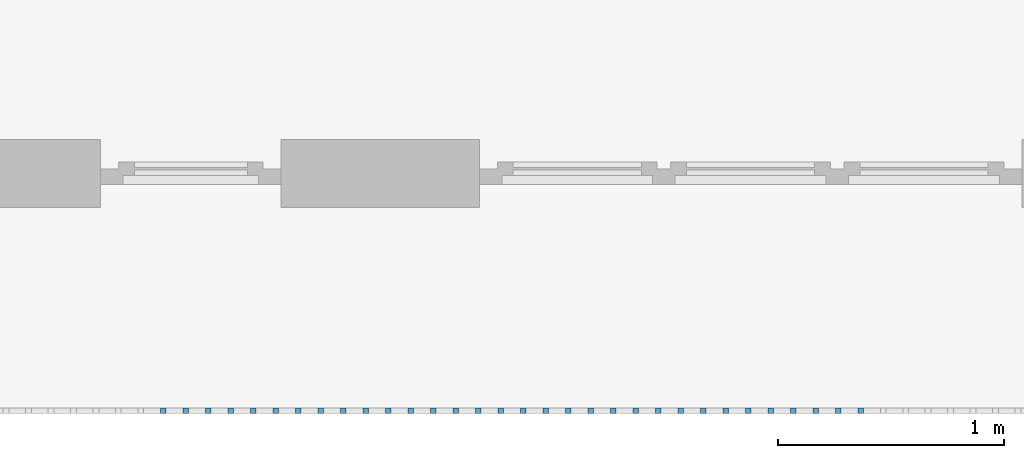
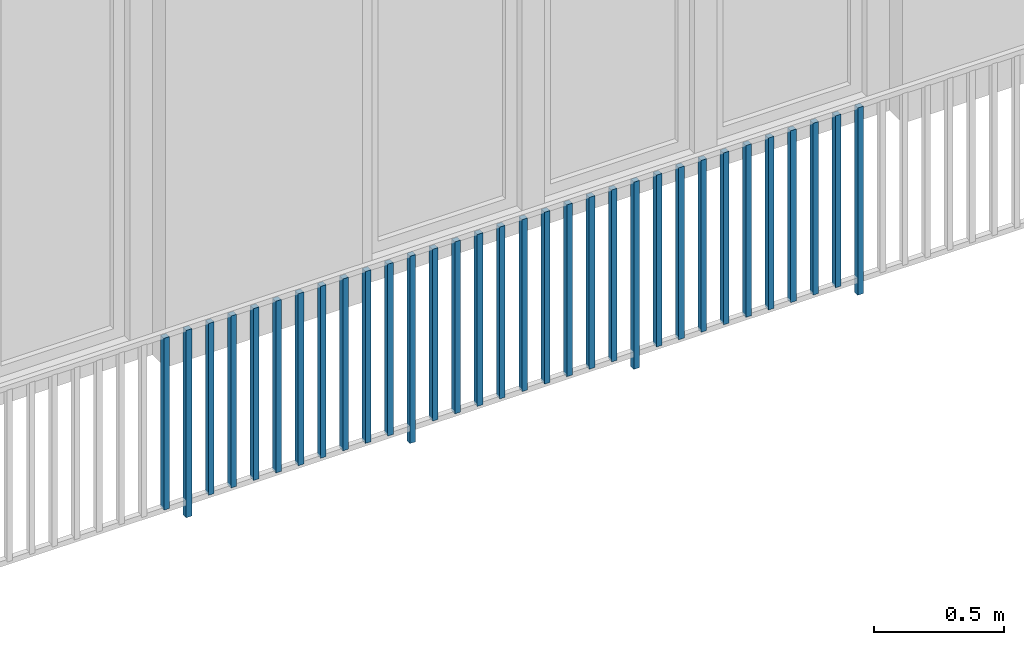
# One storey, part 36 of 54: 32 building element parts, 1 element without a shape of its own.
"""IFC4 building model written with IfcOpenShell, lengths in metres."""

from ifc_helpers import new_model, entity, si_unit, converted_unit, derived_unit, direction, frame, origin_with_axes, place, context, subcontext, project, spatial, polygons, material, type_object, element, aggregate, save


model = new_model("IFC4")

# Units and contexts
model_context = context("Model", 3, precision=1e-05, world=origin_with_axes(), true_north=direction((0.0, 1.0)))
body_context = subcontext(model_context, "Body", "Model", "MODEL_VIEW")
ifc_project = project(units=[si_unit("LENGTHUNIT", "METRE"), si_unit("AREAUNIT", "SQUARE_METRE"), si_unit("VOLUMEUNIT", "CUBIC_METRE"), converted_unit("PLANEANGLEUNIT", "DEGREE", entity("IfcPlaneAngleMeasure", 0.0174532925199), si_unit("PLANEANGLEUNIT", "RADIAN"), dimensions=[0, 0, 0, 0, 0, 0, 0]), converted_unit("TIMEUNIT", "Year", entity("IfcTimeMeasure", 31556926.0), si_unit("TIMEUNIT", "SECOND"), dimensions=[0, 0, 1, 0, 0, 0, 0]), si_unit("MASSUNIT", "GRAM", prefix="KILO"), si_unit("THERMODYNAMICTEMPERATUREUNIT", "DEGREE_CELSIUS"), si_unit("LUMINOUSINTENSITYUNIT", "LUMEN"), si_unit("ENERGYUNIT", "JOULE", prefix="MEGA"), derived_unit("THERMALCONDUCTANCEUNIT", [(si_unit("POWERUNIT", "WATT"), 1), (si_unit("LENGTHUNIT", "METRE"), -1), (si_unit("THERMODYNAMICTEMPERATUREUNIT", "KELVIN"), -1)]), derived_unit("SPECIFICHEATCAPACITYUNIT", [(si_unit("ENERGYUNIT", "JOULE"), 1), (si_unit("MASSUNIT", "GRAM", prefix="KILO"), -1), (si_unit("THERMODYNAMICTEMPERATUREUNIT", "KELVIN"), -1)]), derived_unit("MASSDENSITYUNIT", [(si_unit("MASSUNIT", "GRAM", prefix="KILO"), 1), (si_unit("VOLUMEUNIT", "CUBIC_METRE"), -1)])], contexts=[model_context])

# Site, building, storey, space
site_placement = place(None, origin_with_axes())
site = spatial("IfcSite", under=ifc_project, at=site_placement, CompositionType="ELEMENT")
building_placement = place(site_placement, origin_with_axes())
building = spatial("IfcBuilding", under=site, at=building_placement, CompositionType="ELEMENT")
storey_placement = place(building_placement, frame((0.0, 0.0, 6.29), z_axis=(0.0, 0.0, 1.0), x_axis=(1.0, 0.0, 0.0)))
storey = spatial("IfcBuildingStorey", under=building, at=storey_placement, Name="2. Geschoss", CompositionType="ELEMENT", Elevation=6.29)
space_placement = place(storey_placement, frame((10.2378006196, 9.82118769833, 0.0), z_axis=(0.0, 0.0, 1.0), x_axis=(-1.0, 0.0, 0.0)))
space = spatial("IfcSpace", under=storey, at=space_placement, CompositionType="ELEMENT", PredefinedType="EXTERNAL")

# Railing, building element parts
railing_type = type_object("IfcRailingType", PredefinedType="NOTDEFINED")
railing_placement = place(space_placement, frame((0.0, -7.06315681498e-08, 0.0), z_axis=(0.0, 0.0, 1.0), x_axis=(-1.0, 0.0, 0.0)))
railing = element("IfcRailing", 1, at=railing_placement, inside=space, type_object=railing_type, PredefinedType="NOTDEFINED")
ifc_material = material()
building_element_part_1_placement = place(railing_placement, origin_with_axes())
building_element_part_1 = element("IfcBuildingElementPart", 2, at=building_element_part_1_placement, material=ifc_material, PredefinedType="NOTDEFINED", context=body_context, shape_type="Tessellation", body=[
    polygons([(-10.0348043478, -20.6625, 0.07), (-10.0348043478, -20.6375, 0.07), (-10.0348043478, -20.6375, 0.8775), (-10.0348043478, -20.6625, 0.8775), (-10.0598043478, -20.6625, 0.07), (-10.0598043478, -20.6375, 0.07), (-10.0598043478, -20.6375, 0.8775), (-10.0598043478, -20.6625, 0.8775)], [[[1, 2, 3, 4]], [[1, 5, 6, 2]], [[2, 6, 7, 3]], [[4, 3, 7, 8]], [[5, 1, 4, 8]], [[6, 5, 8, 7]]], closed=True),
])
building_element_part_2_placement = place(railing_placement, origin_with_axes())
building_element_part_2 = element("IfcBuildingElementPart", 3, at=building_element_part_2_placement, material=ifc_material, PredefinedType="NOTDEFINED", context=body_context, shape_type="Tessellation", body=[
    polygons([(-9.93532608696, -20.6625, 0.0), (-9.93532608696, -20.6375, 0.0), (-9.93532608696, -20.6375, 0.88), (-9.93532608696, -20.6625, 0.88), (-9.96032608696, -20.6625, 0.0), (-9.96032608696, -20.6375, 0.0), (-9.96032608696, -20.6375, 0.88), (-9.96032608696, -20.6625, 0.88)], [[[1, 2, 3, 4]], [[1, 5, 6, 2]], [[2, 6, 7, 3]], [[4, 3, 7, 8]], [[5, 1, 4, 8]], [[6, 5, 8, 7]]], closed=True),
])
building_element_part_3_placement = place(railing_placement, origin_with_axes())
building_element_part_3 = element("IfcBuildingElementPart", 4, at=building_element_part_3_placement, material=ifc_material, PredefinedType="NOTDEFINED", context=body_context, shape_type="Tessellation", body=[
    polygons([(-9.83584782609, -20.6625, 0.07), (-9.83584782609, -20.6375, 0.07), (-9.83584782609, -20.6375, 0.8775), (-9.83584782609, -20.6625, 0.8775), (-9.86084782609, -20.6625, 0.07), (-9.86084782609, -20.6375, 0.07), (-9.86084782609, -20.6375, 0.8775), (-9.86084782609, -20.6625, 0.8775)], [[[1, 2, 3, 4]], [[1, 5, 6, 2]], [[2, 6, 7, 3]], [[4, 3, 7, 8]], [[5, 1, 4, 8]], [[6, 5, 8, 7]]], closed=True),
])
building_element_part_4_placement = place(railing_placement, origin_with_axes())
building_element_part_4 = element("IfcBuildingElementPart", 5, at=building_element_part_4_placement, material=ifc_material, PredefinedType="NOTDEFINED", context=body_context, shape_type="Tessellation", body=[
    polygons([(-9.73636956522, -20.6625, 0.07), (-9.73636956522, -20.6375, 0.07), (-9.73636956522, -20.6375, 0.8775), (-9.73636956522, -20.6625, 0.8775), (-9.76136956522, -20.6625, 0.07), (-9.76136956522, -20.6375, 0.07), (-9.76136956522, -20.6375, 0.8775), (-9.76136956522, -20.6625, 0.8775)], [[[1, 2, 3, 4]], [[1, 5, 6, 2]], [[2, 6, 7, 3]], [[4, 3, 7, 8]], [[5, 1, 4, 8]], [[6, 5, 8, 7]]], closed=True),
])
building_element_part_5_placement = place(railing_placement, origin_with_axes())
building_element_part_5 = element("IfcBuildingElementPart", 6, at=building_element_part_5_placement, material=ifc_material, PredefinedType="NOTDEFINED", context=body_context, shape_type="Tessellation", body=[
    polygons([(-9.63689130435, -20.6625, 0.07), (-9.63689130435, -20.6375, 0.07), (-9.63689130435, -20.6375, 0.8775), (-9.63689130435, -20.6625, 0.8775), (-9.66189130435, -20.6625, 0.07), (-9.66189130435, -20.6375, 0.07), (-9.66189130435, -20.6375, 0.8775), (-9.66189130435, -20.6625, 0.8775)], [[[1, 2, 3, 4]], [[1, 5, 6, 2]], [[2, 6, 7, 3]], [[4, 3, 7, 8]], [[5, 1, 4, 8]], [[6, 5, 8, 7]]], closed=True),
])
building_element_part_6_placement = place(railing_placement, origin_with_axes())
building_element_part_6 = element("IfcBuildingElementPart", 7, at=building_element_part_6_placement, material=ifc_material, PredefinedType="NOTDEFINED", context=body_context, shape_type="Tessellation", body=[
    polygons([(-9.53741304348, -20.6625, 0.07), (-9.53741304348, -20.6375, 0.07), (-9.53741304348, -20.6375, 0.8775), (-9.53741304348, -20.6625, 0.8775), (-9.56241304348, -20.6625, 0.07), (-9.56241304348, -20.6375, 0.07), (-9.56241304348, -20.6375, 0.8775), (-9.56241304348, -20.6625, 0.8775)], [[[1, 2, 3, 4]], [[1, 5, 6, 2]], [[2, 6, 7, 3]], [[4, 3, 7, 8]], [[5, 1, 4, 8]], [[6, 5, 8, 7]]], closed=True),
])
building_element_part_7_placement = place(railing_placement, origin_with_axes())
building_element_part_7 = element("IfcBuildingElementPart", 8, at=building_element_part_7_placement, material=ifc_material, PredefinedType="NOTDEFINED", context=body_context, shape_type="Tessellation", body=[
    polygons([(-9.43793478261, -20.6625, 0.07), (-9.43793478261, -20.6375, 0.07), (-9.43793478261, -20.6375, 0.8775), (-9.43793478261, -20.6625, 0.8775), (-9.46293478261, -20.6625, 0.07), (-9.46293478261, -20.6375, 0.07), (-9.46293478261, -20.6375, 0.8775), (-9.46293478261, -20.6625, 0.8775)], [[[1, 2, 3, 4]], [[1, 5, 6, 2]], [[2, 6, 7, 3]], [[4, 3, 7, 8]], [[5, 1, 4, 8]], [[6, 5, 8, 7]]], closed=True),
])
building_element_part_8_placement = place(railing_placement, origin_with_axes())
building_element_part_8 = element("IfcBuildingElementPart", 9, at=building_element_part_8_placement, material=ifc_material, PredefinedType="NOTDEFINED", context=body_context, shape_type="Tessellation", body=[
    polygons([(-9.33845652174, -20.6625, 0.07), (-9.33845652174, -20.6375, 0.07), (-9.33845652174, -20.6375, 0.8775), (-9.33845652174, -20.6625, 0.8775), (-9.36345652174, -20.6625, 0.07), (-9.36345652174, -20.6375, 0.07), (-9.36345652174, -20.6375, 0.8775), (-9.36345652174, -20.6625, 0.8775)], [[[1, 2, 3, 4]], [[1, 5, 6, 2]], [[2, 6, 7, 3]], [[4, 3, 7, 8]], [[5, 1, 4, 8]], [[6, 5, 8, 7]]], closed=True),
])
building_element_part_9_placement = place(railing_placement, origin_with_axes())
building_element_part_9 = element("IfcBuildingElementPart", 10, at=building_element_part_9_placement, material=ifc_material, PredefinedType="NOTDEFINED", context=body_context, shape_type="Tessellation", body=[
    polygons([(-9.23897826087, -20.6625, 0.07), (-9.23897826087, -20.6375, 0.07), (-9.23897826087, -20.6375, 0.8775), (-9.23897826087, -20.6625, 0.8775), (-9.26397826087, -20.6625, 0.07), (-9.26397826087, -20.6375, 0.07), (-9.26397826087, -20.6375, 0.8775), (-9.26397826087, -20.6625, 0.8775)], [[[1, 2, 3, 4]], [[1, 5, 6, 2]], [[2, 6, 7, 3]], [[4, 3, 7, 8]], [[5, 1, 4, 8]], [[6, 5, 8, 7]]], closed=True),
])
building_element_part_10_placement = place(railing_placement, origin_with_axes())
building_element_part_10 = element("IfcBuildingElementPart", 11, at=building_element_part_10_placement, material=ifc_material, PredefinedType="NOTDEFINED", context=body_context, shape_type="Tessellation", body=[
    polygons([(-9.1395, -20.6625, 0.07), (-9.1395, -20.6375, 0.07), (-9.1395, -20.6375, 0.8775), (-9.1395, -20.6625, 0.8775), (-9.1645, -20.6625, 0.07), (-9.1645, -20.6375, 0.07), (-9.1645, -20.6375, 0.8775), (-9.1645, -20.6625, 0.8775)], [[[1, 2, 3, 4]], [[1, 5, 6, 2]], [[2, 6, 7, 3]], [[4, 3, 7, 8]], [[5, 1, 4, 8]], [[6, 5, 8, 7]]], closed=True),
])
building_element_part_11_placement = place(railing_placement, origin_with_axes())
building_element_part_11 = element("IfcBuildingElementPart", 12, at=building_element_part_11_placement, material=ifc_material, PredefinedType="NOTDEFINED", context=body_context, shape_type="Tessellation", body=[
    polygons([(-9.04002173913, -20.6625, 0.07), (-9.04002173913, -20.6375, 0.07), (-9.04002173913, -20.6375, 0.8775), (-9.04002173913, -20.6625, 0.8775), (-9.06502173913, -20.6625, 0.07), (-9.06502173913, -20.6375, 0.07), (-9.06502173913, -20.6375, 0.8775), (-9.06502173913, -20.6625, 0.8775)], [[[1, 2, 3, 4]], [[1, 5, 6, 2]], [[2, 6, 7, 3]], [[4, 3, 7, 8]], [[5, 1, 4, 8]], [[6, 5, 8, 7]]], closed=True),
])
building_element_part_12_placement = place(railing_placement, origin_with_axes())
building_element_part_12 = element("IfcBuildingElementPart", 13, at=building_element_part_12_placement, material=ifc_material, PredefinedType="NOTDEFINED", context=body_context, shape_type="Tessellation", body=[
    polygons([(-8.94054347826, -20.6625, 0.0), (-8.94054347826, -20.6375, 0.0), (-8.94054347826, -20.6375, 0.88), (-8.94054347826, -20.6625, 0.88), (-8.96554347826, -20.6625, 0.0), (-8.96554347826, -20.6375, 0.0), (-8.96554347826, -20.6375, 0.88), (-8.96554347826, -20.6625, 0.88)], [[[1, 2, 3, 4]], [[1, 5, 6, 2]], [[2, 6, 7, 3]], [[4, 3, 7, 8]], [[5, 1, 4, 8]], [[6, 5, 8, 7]]], closed=True),
])
building_element_part_13_placement = place(railing_placement, origin_with_axes())
building_element_part_13 = element("IfcBuildingElementPart", 14, at=building_element_part_13_placement, material=ifc_material, PredefinedType="NOTDEFINED", context=body_context, shape_type="Tessellation", body=[
    polygons([(-8.84106521739, -20.6625, 0.07), (-8.84106521739, -20.6375, 0.07), (-8.84106521739, -20.6375, 0.8775), (-8.84106521739, -20.6625, 0.8775), (-8.86606521739, -20.6625, 0.07), (-8.86606521739, -20.6375, 0.07), (-8.86606521739, -20.6375, 0.8775), (-8.86606521739, -20.6625, 0.8775)], [[[1, 2, 3, 4]], [[1, 5, 6, 2]], [[2, 6, 7, 3]], [[4, 3, 7, 8]], [[5, 1, 4, 8]], [[6, 5, 8, 7]]], closed=True),
])
building_element_part_14_placement = place(railing_placement, origin_with_axes())
building_element_part_14 = element("IfcBuildingElementPart", 15, at=building_element_part_14_placement, material=ifc_material, PredefinedType="NOTDEFINED", context=body_context, shape_type="Tessellation", body=[
    polygons([(-8.74158695652, -20.6625, 0.07), (-8.74158695652, -20.6375, 0.07), (-8.74158695652, -20.6375, 0.8775), (-8.74158695652, -20.6625, 0.8775), (-8.76658695652, -20.6625, 0.07), (-8.76658695652, -20.6375, 0.07), (-8.76658695652, -20.6375, 0.8775), (-8.76658695652, -20.6625, 0.8775)], [[[1, 2, 3, 4]], [[1, 5, 6, 2]], [[2, 6, 7, 3]], [[4, 3, 7, 8]], [[5, 1, 4, 8]], [[6, 5, 8, 7]]], closed=True),
])
building_element_part_15_placement = place(railing_placement, origin_with_axes())
building_element_part_15 = element("IfcBuildingElementPart", 16, at=building_element_part_15_placement, material=ifc_material, PredefinedType="NOTDEFINED", context=body_context, shape_type="Tessellation", body=[
    polygons([(-8.64210869565, -20.6625, 0.07), (-8.64210869565, -20.6375, 0.07), (-8.64210869565, -20.6375, 0.8775), (-8.64210869565, -20.6625, 0.8775), (-8.66710869565, -20.6625, 0.07), (-8.66710869565, -20.6375, 0.07), (-8.66710869565, -20.6375, 0.8775), (-8.66710869565, -20.6625, 0.8775)], [[[1, 2, 3, 4]], [[1, 5, 6, 2]], [[2, 6, 7, 3]], [[4, 3, 7, 8]], [[5, 1, 4, 8]], [[6, 5, 8, 7]]], closed=True),
])
building_element_part_16_placement = place(railing_placement, origin_with_axes())
building_element_part_16 = element("IfcBuildingElementPart", 17, at=building_element_part_16_placement, material=ifc_material, PredefinedType="NOTDEFINED", context=body_context, shape_type="Tessellation", body=[
    polygons([(-8.54263043478, -20.6625, 0.07), (-8.54263043478, -20.6375, 0.07), (-8.54263043478, -20.6375, 0.8775), (-8.54263043478, -20.6625, 0.8775), (-8.56763043478, -20.6625, 0.07), (-8.56763043478, -20.6375, 0.07), (-8.56763043478, -20.6375, 0.8775), (-8.56763043478, -20.6625, 0.8775)], [[[1, 2, 3, 4]], [[1, 5, 6, 2]], [[2, 6, 7, 3]], [[4, 3, 7, 8]], [[5, 1, 4, 8]], [[6, 5, 8, 7]]], closed=True),
])
building_element_part_17_placement = place(railing_placement, origin_with_axes())
building_element_part_17 = element("IfcBuildingElementPart", 18, at=building_element_part_17_placement, material=ifc_material, PredefinedType="NOTDEFINED", context=body_context, shape_type="Tessellation", body=[
    polygons([(-8.44315217391, -20.6625, 0.07), (-8.44315217391, -20.6375, 0.07), (-8.44315217391, -20.6375, 0.8775), (-8.44315217391, -20.6625, 0.8775), (-8.46815217391, -20.6625, 0.07), (-8.46815217391, -20.6375, 0.07), (-8.46815217391, -20.6375, 0.8775), (-8.46815217391, -20.6625, 0.8775)], [[[1, 2, 3, 4]], [[1, 5, 6, 2]], [[2, 6, 7, 3]], [[4, 3, 7, 8]], [[5, 1, 4, 8]], [[6, 5, 8, 7]]], closed=True),
])
building_element_part_18_placement = place(railing_placement, origin_with_axes())
building_element_part_18 = element("IfcBuildingElementPart", 19, at=building_element_part_18_placement, material=ifc_material, PredefinedType="NOTDEFINED", context=body_context, shape_type="Tessellation", body=[
    polygons([(-8.34367391304, -20.6625, 0.07), (-8.34367391304, -20.6375, 0.07), (-8.34367391304, -20.6375, 0.8775), (-8.34367391304, -20.6625, 0.8775), (-8.36867391304, -20.6625, 0.07), (-8.36867391304, -20.6375, 0.07), (-8.36867391304, -20.6375, 0.8775), (-8.36867391304, -20.6625, 0.8775)], [[[1, 2, 3, 4]], [[1, 5, 6, 2]], [[2, 6, 7, 3]], [[4, 3, 7, 8]], [[5, 1, 4, 8]], [[6, 5, 8, 7]]], closed=True),
])
building_element_part_19_placement = place(railing_placement, origin_with_axes())
building_element_part_19 = element("IfcBuildingElementPart", 20, at=building_element_part_19_placement, material=ifc_material, PredefinedType="NOTDEFINED", context=body_context, shape_type="Tessellation", body=[
    polygons([(-8.24419565217, -20.6625, 0.07), (-8.24419565217, -20.6375, 0.07), (-8.24419565217, -20.6375, 0.8775), (-8.24419565217, -20.6625, 0.8775), (-8.26919565217, -20.6625, 0.07), (-8.26919565217, -20.6375, 0.07), (-8.26919565217, -20.6375, 0.8775), (-8.26919565217, -20.6625, 0.8775)], [[[1, 2, 3, 4]], [[1, 5, 6, 2]], [[2, 6, 7, 3]], [[4, 3, 7, 8]], [[5, 1, 4, 8]], [[6, 5, 8, 7]]], closed=True),
])
building_element_part_20_placement = place(railing_placement, origin_with_axes())
building_element_part_20 = element("IfcBuildingElementPart", 21, at=building_element_part_20_placement, material=ifc_material, PredefinedType="NOTDEFINED", context=body_context, shape_type="Tessellation", body=[
    polygons([(-8.1447173913, -20.6625, 0.07), (-8.1447173913, -20.6375, 0.07), (-8.1447173913, -20.6375, 0.8775), (-8.1447173913, -20.6625, 0.8775), (-8.1697173913, -20.6625, 0.07), (-8.1697173913, -20.6375, 0.07), (-8.1697173913, -20.6375, 0.8775), (-8.1697173913, -20.6625, 0.8775)], [[[1, 2, 3, 4]], [[1, 5, 6, 2]], [[2, 6, 7, 3]], [[4, 3, 7, 8]], [[5, 1, 4, 8]], [[6, 5, 8, 7]]], closed=True),
])
building_element_part_21_placement = place(railing_placement, origin_with_axes())
building_element_part_21 = element("IfcBuildingElementPart", 22, at=building_element_part_21_placement, material=ifc_material, PredefinedType="NOTDEFINED", context=body_context, shape_type="Tessellation", body=[
    polygons([(-8.04523913043, -20.6625, 0.07), (-8.04523913043, -20.6375, 0.07), (-8.04523913043, -20.6375, 0.8775), (-8.04523913043, -20.6625, 0.8775), (-8.07023913043, -20.6625, 0.07), (-8.07023913043, -20.6375, 0.07), (-8.07023913043, -20.6375, 0.8775), (-8.07023913043, -20.6625, 0.8775)], [[[1, 2, 3, 4]], [[1, 5, 6, 2]], [[2, 6, 7, 3]], [[4, 3, 7, 8]], [[5, 1, 4, 8]], [[6, 5, 8, 7]]], closed=True),
])
building_element_part_22_placement = place(railing_placement, origin_with_axes())
building_element_part_22 = element("IfcBuildingElementPart", 23, at=building_element_part_22_placement, material=ifc_material, PredefinedType="NOTDEFINED", context=body_context, shape_type="Tessellation", body=[
    polygons([(-7.94576086957, -20.6625, 0.0), (-7.94576086957, -20.6375, 0.0), (-7.94576086957, -20.6375, 0.88), (-7.94576086957, -20.6625, 0.88), (-7.97076086957, -20.6625, 0.0), (-7.97076086957, -20.6375, 0.0), (-7.97076086957, -20.6375, 0.88), (-7.97076086957, -20.6625, 0.88)], [[[1, 2, 3, 4]], [[1, 5, 6, 2]], [[2, 6, 7, 3]], [[4, 3, 7, 8]], [[5, 1, 4, 8]], [[6, 5, 8, 7]]], closed=True),
])
building_element_part_23_placement = place(railing_placement, origin_with_axes())
building_element_part_23 = element("IfcBuildingElementPart", 24, at=building_element_part_23_placement, material=ifc_material, PredefinedType="NOTDEFINED", context=body_context, shape_type="Tessellation", body=[
    polygons([(-7.8462826087, -20.6625, 0.07), (-7.8462826087, -20.6375, 0.07), (-7.8462826087, -20.6375, 0.8775), (-7.8462826087, -20.6625, 0.8775), (-7.8712826087, -20.6625, 0.07), (-7.8712826087, -20.6375, 0.07), (-7.8712826087, -20.6375, 0.8775), (-7.8712826087, -20.6625, 0.8775)], [[[1, 2, 3, 4]], [[1, 5, 6, 2]], [[2, 6, 7, 3]], [[4, 3, 7, 8]], [[5, 1, 4, 8]], [[6, 5, 8, 7]]], closed=True),
])
building_element_part_24_placement = place(railing_placement, origin_with_axes())
building_element_part_24 = element("IfcBuildingElementPart", 25, at=building_element_part_24_placement, material=ifc_material, PredefinedType="NOTDEFINED", context=body_context, shape_type="Tessellation", body=[
    polygons([(-7.74680434783, -20.6625, 0.07), (-7.74680434783, -20.6375, 0.07), (-7.74680434783, -20.6375, 0.8775), (-7.74680434783, -20.6625, 0.8775), (-7.77180434783, -20.6625, 0.07), (-7.77180434783, -20.6375, 0.07), (-7.77180434783, -20.6375, 0.8775), (-7.77180434783, -20.6625, 0.8775)], [[[1, 2, 3, 4]], [[1, 5, 6, 2]], [[2, 6, 7, 3]], [[4, 3, 7, 8]], [[5, 1, 4, 8]], [[6, 5, 8, 7]]], closed=True),
])
building_element_part_25_placement = place(railing_placement, origin_with_axes())
building_element_part_25 = element("IfcBuildingElementPart", 26, at=building_element_part_25_placement, material=ifc_material, PredefinedType="NOTDEFINED", context=body_context, shape_type="Tessellation", body=[
    polygons([(-7.64732608696, -20.6625, 0.07), (-7.64732608696, -20.6375, 0.07), (-7.64732608696, -20.6375, 0.8775), (-7.64732608696, -20.6625, 0.8775), (-7.67232608696, -20.6625, 0.07), (-7.67232608696, -20.6375, 0.07), (-7.67232608696, -20.6375, 0.8775), (-7.67232608696, -20.6625, 0.8775)], [[[1, 2, 3, 4]], [[1, 5, 6, 2]], [[2, 6, 7, 3]], [[4, 3, 7, 8]], [[5, 1, 4, 8]], [[6, 5, 8, 7]]], closed=True),
])
building_element_part_26_placement = place(railing_placement, origin_with_axes())
building_element_part_26 = element("IfcBuildingElementPart", 27, at=building_element_part_26_placement, material=ifc_material, PredefinedType="NOTDEFINED", context=body_context, shape_type="Tessellation", body=[
    polygons([(-7.54784782609, -20.6625, 0.07), (-7.54784782609, -20.6375, 0.07), (-7.54784782609, -20.6375, 0.8775), (-7.54784782609, -20.6625, 0.8775), (-7.57284782609, -20.6625, 0.07), (-7.57284782609, -20.6375, 0.07), (-7.57284782609, -20.6375, 0.8775), (-7.57284782609, -20.6625, 0.8775)], [[[1, 2, 3, 4]], [[1, 5, 6, 2]], [[2, 6, 7, 3]], [[4, 3, 7, 8]], [[5, 1, 4, 8]], [[6, 5, 8, 7]]], closed=True),
])
building_element_part_27_placement = place(railing_placement, origin_with_axes())
building_element_part_27 = element("IfcBuildingElementPart", 28, at=building_element_part_27_placement, material=ifc_material, PredefinedType="NOTDEFINED", context=body_context, shape_type="Tessellation", body=[
    polygons([(-7.44836956522, -20.6625, 0.07), (-7.44836956522, -20.6375, 0.07), (-7.44836956522, -20.6375, 0.8775), (-7.44836956522, -20.6625, 0.8775), (-7.47336956522, -20.6625, 0.07), (-7.47336956522, -20.6375, 0.07), (-7.47336956522, -20.6375, 0.8775), (-7.47336956522, -20.6625, 0.8775)], [[[1, 2, 3, 4]], [[1, 5, 6, 2]], [[2, 6, 7, 3]], [[4, 3, 7, 8]], [[5, 1, 4, 8]], [[6, 5, 8, 7]]], closed=True),
])
building_element_part_28_placement = place(railing_placement, origin_with_axes())
building_element_part_28 = element("IfcBuildingElementPart", 29, at=building_element_part_28_placement, material=ifc_material, PredefinedType="NOTDEFINED", context=body_context, shape_type="Tessellation", body=[
    polygons([(-7.34889130435, -20.6625, 0.07), (-7.34889130435, -20.6375, 0.07), (-7.34889130435, -20.6375, 0.8775), (-7.34889130435, -20.6625, 0.8775), (-7.37389130435, -20.6625, 0.07), (-7.37389130435, -20.6375, 0.07), (-7.37389130435, -20.6375, 0.8775), (-7.37389130435, -20.6625, 0.8775)], [[[1, 2, 3, 4]], [[1, 5, 6, 2]], [[2, 6, 7, 3]], [[4, 3, 7, 8]], [[5, 1, 4, 8]], [[6, 5, 8, 7]]], closed=True),
])
building_element_part_29_placement = place(railing_placement, origin_with_axes())
building_element_part_29 = element("IfcBuildingElementPart", 30, at=building_element_part_29_placement, material=ifc_material, PredefinedType="NOTDEFINED", context=body_context, shape_type="Tessellation", body=[
    polygons([(-7.24941304348, -20.6625, 0.07), (-7.24941304348, -20.6375, 0.07), (-7.24941304348, -20.6375, 0.8775), (-7.24941304348, -20.6625, 0.8775), (-7.27441304348, -20.6625, 0.07), (-7.27441304348, -20.6375, 0.07), (-7.27441304348, -20.6375, 0.8775), (-7.27441304348, -20.6625, 0.8775)], [[[1, 2, 3, 4]], [[1, 5, 6, 2]], [[2, 6, 7, 3]], [[4, 3, 7, 8]], [[5, 1, 4, 8]], [[6, 5, 8, 7]]], closed=True),
])
building_element_part_30_placement = place(railing_placement, origin_with_axes())
building_element_part_30 = element("IfcBuildingElementPart", 31, at=building_element_part_30_placement, material=ifc_material, PredefinedType="NOTDEFINED", context=body_context, shape_type="Tessellation", body=[
    polygons([(-7.14993478261, -20.6625, 0.07), (-7.14993478261, -20.6375, 0.07), (-7.14993478261, -20.6375, 0.8775), (-7.14993478261, -20.6625, 0.8775), (-7.17493478261, -20.6625, 0.07), (-7.17493478261, -20.6375, 0.07), (-7.17493478261, -20.6375, 0.8775), (-7.17493478261, -20.6625, 0.8775)], [[[1, 2, 3, 4]], [[1, 5, 6, 2]], [[2, 6, 7, 3]], [[4, 3, 7, 8]], [[5, 1, 4, 8]], [[6, 5, 8, 7]]], closed=True),
])
building_element_part_31_placement = place(railing_placement, origin_with_axes())
building_element_part_31 = element("IfcBuildingElementPart", 32, at=building_element_part_31_placement, material=ifc_material, PredefinedType="NOTDEFINED", context=body_context, shape_type="Tessellation", body=[
    polygons([(-7.05045652174, -20.6625, 0.07), (-7.05045652174, -20.6375, 0.07), (-7.05045652174, -20.6375, 0.8775), (-7.05045652174, -20.6625, 0.8775), (-7.07545652174, -20.6625, 0.07), (-7.07545652174, -20.6375, 0.07), (-7.07545652174, -20.6375, 0.8775), (-7.07545652174, -20.6625, 0.8775)], [[[1, 2, 3, 4]], [[1, 5, 6, 2]], [[2, 6, 7, 3]], [[4, 3, 7, 8]], [[5, 1, 4, 8]], [[6, 5, 8, 7]]], closed=True),
])
building_element_part_32_placement = place(railing_placement, origin_with_axes())
building_element_part_32 = element("IfcBuildingElementPart", 33, at=building_element_part_32_placement, material=ifc_material, PredefinedType="NOTDEFINED", context=body_context, shape_type="Tessellation", body=[
    polygons([(-6.95097826087, -20.6625, 0.0), (-6.95097826087, -20.6375, 0.0), (-6.95097826087, -20.6375, 0.88), (-6.95097826087, -20.6625, 0.88), (-6.97597826087, -20.6625, 0.0), (-6.97597826087, -20.6375, 0.0), (-6.97597826087, -20.6375, 0.88), (-6.97597826087, -20.6625, 0.88)], [[[1, 2, 3, 4]], [[1, 5, 6, 2]], [[2, 6, 7, 3]], [[4, 3, 7, 8]], [[5, 1, 4, 8]], [[6, 5, 8, 7]]], closed=True),
])
aggregate(railing, [building_element_part_1, building_element_part_2, building_element_part_3, building_element_part_4, building_element_part_5, building_element_part_6, building_element_part_7, building_element_part_8, building_element_part_9, building_element_part_10, building_element_part_11, building_element_part_12, building_element_part_13, building_element_part_14, building_element_part_15, building_element_part_16, building_element_part_17, building_element_part_18, building_element_part_19, building_element_part_20, building_element_part_21, building_element_part_22, building_element_part_23, building_element_part_24, building_element_part_25, building_element_part_26, building_element_part_27, building_element_part_28, building_element_part_29, building_element_part_30, building_element_part_31, building_element_part_32])

save(model, "model.ifc")
